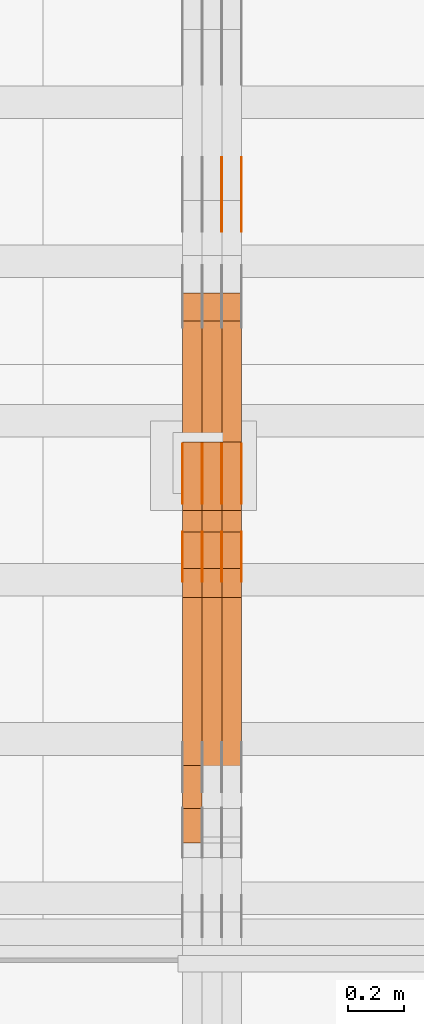
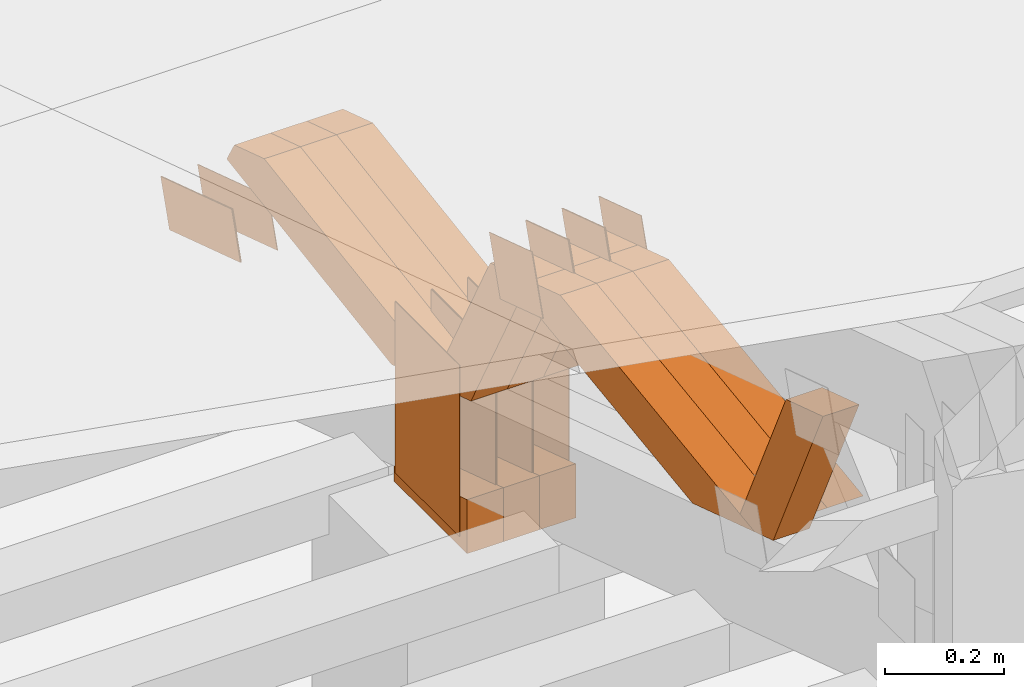
# One storey, part 151 of 385: 28 proxies.
"""IFC2X3 building model written with IfcOpenShell, lengths in millimetres."""

from ifc_helpers import new_model, entity, si_unit, converted_unit, derived_unit, direction, frame, origin, origin_2d_with_axis, place, context, subcontext, project, spatial, polyline, rectangle, outline, extrude, source, transform, mapped, material, type_object, type_shapes, element, save


model = new_model("IFC2X3")

# Units and contexts
model_context = context("Model", 3, precision=0.01, world=origin(), true_north=direction((6.12303176911189e-17, 1.0)))
body_context = subcontext(model_context, "Body", "Model", "MODEL_VIEW")
ifc_project = project(units=[si_unit("LENGTHUNIT", "METRE", prefix="MILLI"), si_unit("AREAUNIT", "SQUARE_METRE"), si_unit("VOLUMEUNIT", "CUBIC_METRE"), converted_unit("PLANEANGLEUNIT", "DEGREE", entity("IfcRatioMeasure", 0.0174532925199433), si_unit("PLANEANGLEUNIT", "RADIAN"), dimensions=[0, 0, 0, 0, 0, 0, 0]), si_unit("MASSUNIT", "GRAM", prefix="KILO"), derived_unit("MASSDENSITYUNIT", [(si_unit("MASSUNIT", "GRAM", prefix="KILO"), 1), (si_unit("LENGTHUNIT", "METRE"), -3)]), si_unit("TIMEUNIT", "SECOND"), si_unit("FREQUENCYUNIT", "HERTZ"), si_unit("THERMODYNAMICTEMPERATUREUNIT", "DEGREE_CELSIUS"), derived_unit("THERMALTRANSMITTANCEUNIT", [(si_unit("MASSUNIT", "GRAM", prefix="KILO"), 1), (si_unit("THERMODYNAMICTEMPERATUREUNIT", "KELVIN"), -1), (si_unit("TIMEUNIT", "SECOND"), -3)]), derived_unit("VOLUMETRICFLOWRATEUNIT", [(si_unit("LENGTHUNIT", "METRE"), 3), (si_unit("TIMEUNIT", "SECOND"), -1)]), si_unit("ELECTRICCURRENTUNIT", "AMPERE"), si_unit("ELECTRICVOLTAGEUNIT", "VOLT"), si_unit("POWERUNIT", "WATT"), si_unit("FORCEUNIT", "NEWTON", prefix="KILO"), si_unit("ILLUMINANCEUNIT", "LUX"), si_unit("LUMINOUSFLUXUNIT", "LUMEN"), si_unit("LUMINOUSINTENSITYUNIT", "CANDELA"), derived_unit("USERDEFINED", [(si_unit("MASSUNIT", "GRAM", prefix="KILO"), -1), (si_unit("LENGTHUNIT", "METRE"), -2), (si_unit("TIMEUNIT", "SECOND"), 3), (si_unit("LUMINOUSFLUXUNIT", "LUMEN"), 1)]), derived_unit("LINEARVELOCITYUNIT", [(si_unit("LENGTHUNIT", "METRE"), 1), (si_unit("TIMEUNIT", "SECOND"), -1)]), si_unit("PRESSUREUNIT", "PASCAL"), derived_unit("USERDEFINED", [(si_unit("LENGTHUNIT", "METRE"), -2), (si_unit("MASSUNIT", "GRAM", prefix="KILO"), 1), (si_unit("TIMEUNIT", "SECOND"), -2)])], contexts=[model_context])

# Site, building, storey
site_placement = place(None, origin())
site = spatial("IfcSite", under=ifc_project, at=site_placement, CompositionType="ELEMENT")
building_placement = place(site_placement, origin())
building = spatial("IfcBuilding", under=site, at=building_placement, CompositionType="ELEMENT")
storey_placement = place(building_placement, origin())
storey = spatial("IfcBuildingStorey", under=building, at=storey_placement, Name="Default", CompositionType="ELEMENT", Elevation=0.0)

# Proxies
ifc_material_1 = material(Name="IfcSurfaceStyle #273558")
building_element_proxy_type_1 = type_object("IfcBuildingElementProxyType", PredefinedType="NOTDEFINED", material=ifc_material_1)
shared_shape_1 = source(origin(), body_context, "Body", "SweptSolid", [
    extrude(outline(polyline([(-125.00031378339, -47.9999612158856), (125.000225258022, -47.9999612158856), (124.999811678525, 47.9999612158856), (-124.999723153156, 47.9999612158856), (-125.00031378339, -47.9999612158856)])), frame((125.000225258022, 48.0000091013474, 0.0), z_axis=(0.0, 0.0, 1.0), x_axis=(-1.0, 0.0, 0.0)), (0.0, 0.0, 1.0), 1.3),
])
type_shapes(building_element_proxy_type_1, [shared_shape_1])
proxy_1_placement = place(building_placement, frame((21386.3, 18456.8597683375, 2657.46691321253), z_axis=(-1.0, 0.0, 0.0), x_axis=(0.0, -0.951056516295124, 0.309016994375039)))
element("IfcBuildingElementProxy", 1, at=proxy_1_placement, inside=storey, type_object=building_element_proxy_type_1, material=ifc_material_1, context=body_context, shape_type="MappedRepresentation", body=[
    mapped(shared_shape_1, transform((0.0, 0.0, 0.0), scale=1.0)),
])
ifc_material_2 = material(Name="IfcSurfaceStyle #273501")
building_element_proxy_type_2 = type_object("IfcBuildingElementProxyType", PredefinedType="NOTDEFINED", material=ifc_material_2)
shared_shape_2 = source(origin(), body_context, "Body", "SweptSolid", [
    extrude(outline(polyline([(-125.00031378339, -47.9999612158856), (125.000225258022, -47.9999612158856), (124.999811678525, 47.9999612158856), (-124.999723153156, 47.9999612158856), (-125.00031378339, -47.9999612158856)])), frame((125.000225258022, 48.0000091013474, 0.0), z_axis=(0.0, 0.0, 1.0), x_axis=(-1.0, 0.0, 0.0)), (0.0, 0.0, 1.0), 1.3),
])
type_shapes(building_element_proxy_type_2, [shared_shape_2])
proxy_2_placement = place(building_placement, frame((21315.0, 18456.8597683375, 2657.46691321253), z_axis=(-1.0, 0.0, 0.0), x_axis=(0.0, -0.951056516295124, 0.309016994375039)))
element("IfcBuildingElementProxy", 2, at=proxy_2_placement, inside=storey, type_object=building_element_proxy_type_2, material=ifc_material_2, context=body_context, shape_type="MappedRepresentation", body=[
    mapped(shared_shape_2, transform((0.0, 0.0, 0.0), scale=1.0)),
])
ifc_material_3 = material(Name="IfcSurfaceStyle #273444")
building_element_proxy_type_3 = type_object("IfcBuildingElementProxyType", PredefinedType="NOTDEFINED", material=ifc_material_3)
shared_shape_3 = source(origin(), body_context, "Body", "SweptSolid", [
    extrude(outline(polyline([(-125.00031378339, -47.9999612158856), (125.000225258022, -47.9999612158856), (124.999811678525, 47.9999612158856), (-124.999723153156, 47.9999612158856), (-125.00031378339, -47.9999612158856)])), frame((125.000225258022, 48.0000091013474, 0.0), z_axis=(0.0, 0.0, 1.0), x_axis=(-1.0, 0.0, 0.0)), (0.0, 0.0, 1.0), 1.3),
])
type_shapes(building_element_proxy_type_3, [shared_shape_3])
proxy_3_placement = place(building_placement, frame((21316.3, 18456.8597683375, 2657.46691321253), z_axis=(-1.0, 0.0, 0.0), x_axis=(0.0, -0.951056516295124, 0.309016994375039)))
element("IfcBuildingElementProxy", 3, at=proxy_3_placement, inside=storey, type_object=building_element_proxy_type_3, material=ifc_material_3, context=body_context, shape_type="MappedRepresentation", body=[
    mapped(shared_shape_3, transform((0.0, 0.0, 0.0), scale=1.0)),
])
ifc_material_4 = material(Name="IfcSurfaceStyle #271506")
building_element_proxy_type_4 = type_object("IfcBuildingElementProxyType", PredefinedType="NOTDEFINED", material=ifc_material_4)
shared_shape_4 = source(origin(), body_context, "Body", "SweptSolid", [
    extrude(rectangle(XDim=350.0, YDim=215.999999999984, at=origin_2d_with_axis()), frame((175.0, 108.0, 0.0), z_axis=(0.0, 0.0, 1.0), x_axis=(-1.0, 0.0, 0.0)), (0.0, 0.0, 1.0), 1.29999999999999),
])
type_shapes(building_element_proxy_type_4, [shared_shape_4])
proxy_4_placement = place(building_placement, frame((21386.3, 17459.2939453125, 3165.36425781251), z_axis=(-1.0, 0.0, 0.0), x_axis=(0.0, 0.0, -1.0)))
element("IfcBuildingElementProxy", 4, at=proxy_4_placement, inside=storey, type_object=building_element_proxy_type_4, material=ifc_material_4, context=body_context, shape_type="MappedRepresentation", body=[
    mapped(shared_shape_4, transform((0.0, 0.0, 0.0), scale=1.0)),
])
ifc_material_5 = material(Name="IfcSurfaceStyle #271449")
building_element_proxy_type_5 = type_object("IfcBuildingElementProxyType", PredefinedType="NOTDEFINED", material=ifc_material_5)
shared_shape_5 = source(origin(), body_context, "Body", "SweptSolid", [
    extrude(rectangle(XDim=350.0, YDim=215.999999999984, at=origin_2d_with_axis()), frame((175.0, 108.0, 0.0), z_axis=(0.0, 0.0, 1.0), x_axis=(-1.0, 0.0, 0.0)), (0.0, 0.0, 1.0), 1.29999999999999),
])
type_shapes(building_element_proxy_type_5, [shared_shape_5])
proxy_5_placement = place(building_placement, frame((21315.0, 17459.2939453125, 3165.36425781251), z_axis=(-1.0, 0.0, 0.0), x_axis=(0.0, 0.0, -1.0)))
element("IfcBuildingElementProxy", 5, at=proxy_5_placement, inside=storey, type_object=building_element_proxy_type_5, material=ifc_material_5, context=body_context, shape_type="MappedRepresentation", body=[
    mapped(shared_shape_5, transform((0.0, 0.0, 0.0), scale=1.0)),
])
ifc_material_6 = material(Name="IfcSurfaceStyle #271392")
building_element_proxy_type_6 = type_object("IfcBuildingElementProxyType", PredefinedType="NOTDEFINED", material=ifc_material_6)
shared_shape_6 = source(origin(), body_context, "Body", "SweptSolid", [
    extrude(rectangle(XDim=350.0, YDim=215.999999999984, at=origin_2d_with_axis()), frame((175.0, 108.0, 0.0), z_axis=(0.0, 0.0, 1.0), x_axis=(-1.0, 0.0, 0.0)), (0.0, 0.0, 1.0), 1.29999999999999),
])
type_shapes(building_element_proxy_type_6, [shared_shape_6])
proxy_6_placement = place(building_placement, frame((21316.3, 17459.2939453125, 3165.36425781251), z_axis=(-1.0, 0.0, 0.0), x_axis=(0.0, 0.0, -1.0)))
element("IfcBuildingElementProxy", 6, at=proxy_6_placement, inside=storey, type_object=building_element_proxy_type_6, material=ifc_material_6, context=body_context, shape_type="MappedRepresentation", body=[
    mapped(shared_shape_6, transform((0.0, 0.0, 0.0), scale=1.0)),
])
ifc_material_7 = material(Name="IfcSurfaceStyle #271335")
building_element_proxy_type_7 = type_object("IfcBuildingElementProxyType", PredefinedType="NOTDEFINED", material=ifc_material_7)
shared_shape_7 = source(origin(), body_context, "Body", "SweptSolid", [
    extrude(rectangle(XDim=350.0, YDim=215.999999999984, at=origin_2d_with_axis()), frame((175.0, 108.0, 0.0), z_axis=(0.0, 0.0, 1.0), x_axis=(-1.0, 0.0, 0.0)), (0.0, 0.0, 1.0), 1.29999999999998),
])
type_shapes(building_element_proxy_type_7, [shared_shape_7])
proxy_7_placement = place(building_placement, frame((21245.0, 17459.2939453125, 3165.36425781251), z_axis=(-1.0, 0.0, 0.0), x_axis=(0.0, 0.0, -1.0)))
element("IfcBuildingElementProxy", 7, at=proxy_7_placement, inside=storey, type_object=building_element_proxy_type_7, material=ifc_material_7, context=body_context, shape_type="MappedRepresentation", body=[
    mapped(shared_shape_7, transform((0.0, 0.0, 0.0), scale=1.0)),
])
ifc_material_8 = material(Name="IfcSurfaceStyle #271278")
building_element_proxy_type_8 = type_object("IfcBuildingElementProxyType", PredefinedType="NOTDEFINED", material=ifc_material_8)
shared_shape_8 = source(origin(), body_context, "Body", "SweptSolid", [
    extrude(rectangle(XDim=350.0, YDim=215.999999999984, at=origin_2d_with_axis()), frame((175.0, 108.0, 0.0), z_axis=(0.0, 0.0, 1.0), x_axis=(-1.0, 0.0, 0.0)), (0.0, 0.0, 1.0), 1.29999999999998),
])
type_shapes(building_element_proxy_type_8, [shared_shape_8])
proxy_8_placement = place(building_placement, frame((21246.3, 17459.2939453125, 3165.36425781251), z_axis=(-1.0, 0.0, 0.0), x_axis=(0.0, 0.0, -1.0)))
element("IfcBuildingElementProxy", 8, at=proxy_8_placement, inside=storey, type_object=building_element_proxy_type_8, material=ifc_material_8, context=body_context, shape_type="MappedRepresentation", body=[
    mapped(shared_shape_8, transform((0.0, 0.0, 0.0), scale=1.0)),
])
ifc_material_9 = material(Name="IfcSurfaceStyle #271221")
building_element_proxy_type_9 = type_object("IfcBuildingElementProxyType", PredefinedType="NOTDEFINED", material=ifc_material_9)
shared_shape_9 = source(origin(), body_context, "Body", "SweptSolid", [
    extrude(rectangle(XDim=350.0, YDim=215.999999999984, at=origin_2d_with_axis()), frame((175.0, 108.0, 0.0), z_axis=(0.0, 0.0, 1.0), x_axis=(-1.0, 0.0, 0.0)), (0.0, 0.0, 1.0), 1.29999999999998),
])
type_shapes(building_element_proxy_type_9, [shared_shape_9])
proxy_9_placement = place(building_placement, frame((21175.0, 17459.2939453125, 3165.36425781251), z_axis=(-1.0, 0.0, 0.0), x_axis=(0.0, 0.0, -1.0)))
element("IfcBuildingElementProxy", 9, at=proxy_9_placement, inside=storey, type_object=building_element_proxy_type_9, material=ifc_material_9, context=body_context, shape_type="MappedRepresentation", body=[
    mapped(shared_shape_9, transform((0.0, 0.0, 0.0), scale=1.0)),
])
ifc_material_10 = material(Name="IfcSurfaceStyle #268086")
building_element_proxy_type_10 = type_object("IfcBuildingElementProxyType", PredefinedType="NOTDEFINED", material=ifc_material_10)
shared_shape_10 = source(origin(), body_context, "Body", "SweptSolid", [
    extrude(outline(polyline([(-74.9998605591058, -59.9999264677524), (74.999875428623, -59.9999264677524), (74.9998605591068, 59.9999264677524), (-74.9998754286239, 59.9999264677524), (-74.9998605591058, -59.9999264677524)])), frame((75.0002460484325, 60.0000016373508, 0.0), z_axis=(0.0, 0.0, 1.0), x_axis=(-1.0, 0.0, 0.0)), (0.0, 0.0, 1.0), 1.3),
])
type_shapes(building_element_proxy_type_10, [shared_shape_10])
proxy_10_placement = place(building_placement, frame((21386.3, 17107.0599369346, 3383.82825001787), z_axis=(-1.0, 0.0, 0.0), x_axis=(0.0, -0.951056516295154, 0.309016994374948)))
element("IfcBuildingElementProxy", 10, at=proxy_10_placement, inside=storey, type_object=building_element_proxy_type_10, material=ifc_material_10, context=body_context, shape_type="MappedRepresentation", body=[
    mapped(shared_shape_10, transform((0.0, 0.0, 0.0), scale=1.0)),
])
ifc_material_11 = material(Name="IfcSurfaceStyle #268029")
building_element_proxy_type_11 = type_object("IfcBuildingElementProxyType", PredefinedType="NOTDEFINED", material=ifc_material_11)
shared_shape_11 = source(origin(), body_context, "Body", "SweptSolid", [
    extrude(outline(polyline([(-74.9998605591058, -59.9999264677524), (74.999875428623, -59.9999264677524), (74.9998605591068, 59.9999264677524), (-74.9998754286239, 59.9999264677524), (-74.9998605591058, -59.9999264677524)])), frame((75.0002460484325, 60.0000016373508, 0.0), z_axis=(0.0, 0.0, 1.0), x_axis=(-1.0, 0.0, 0.0)), (0.0, 0.0, 1.0), 1.3),
])
type_shapes(building_element_proxy_type_11, [shared_shape_11])
proxy_11_placement = place(building_placement, frame((21315.0, 17107.0599369346, 3383.82825001787), z_axis=(-1.0, 0.0, 0.0), x_axis=(0.0, -0.951056516295154, 0.309016994374948)))
element("IfcBuildingElementProxy", 11, at=proxy_11_placement, inside=storey, type_object=building_element_proxy_type_11, material=ifc_material_11, context=body_context, shape_type="MappedRepresentation", body=[
    mapped(shared_shape_11, transform((0.0, 0.0, 0.0), scale=1.0)),
])
ifc_material_12 = material(Name="IfcSurfaceStyle #267972")
building_element_proxy_type_12 = type_object("IfcBuildingElementProxyType", PredefinedType="NOTDEFINED", material=ifc_material_12)
shared_shape_12 = source(origin(), body_context, "Body", "SweptSolid", [
    extrude(outline(polyline([(-74.9998605591058, -59.9999264677524), (74.999875428623, -59.9999264677524), (74.9998605591068, 59.9999264677524), (-74.9998754286239, 59.9999264677524), (-74.9998605591058, -59.9999264677524)])), frame((75.0002460484325, 60.0000016373508, 0.0), z_axis=(0.0, 0.0, 1.0), x_axis=(-1.0, 0.0, 0.0)), (0.0, 0.0, 1.0), 1.3),
])
type_shapes(building_element_proxy_type_12, [shared_shape_12])
proxy_12_placement = place(building_placement, frame((21316.3, 17107.0599369346, 3383.82825001787), z_axis=(-1.0, 0.0, 0.0), x_axis=(0.0, -0.951056516295154, 0.309016994374948)))
element("IfcBuildingElementProxy", 12, at=proxy_12_placement, inside=storey, type_object=building_element_proxy_type_12, material=ifc_material_12, context=body_context, shape_type="MappedRepresentation", body=[
    mapped(shared_shape_12, transform((0.0, 0.0, 0.0), scale=1.0)),
])
ifc_material_13 = material(Name="IfcSurfaceStyle #267915")
building_element_proxy_type_13 = type_object("IfcBuildingElementProxyType", PredefinedType="NOTDEFINED", material=ifc_material_13)
shared_shape_13 = source(origin(), body_context, "Body", "SweptSolid", [
    extrude(outline(polyline([(-74.9998605591058, -59.9999264677524), (74.999875428623, -59.9999264677524), (74.9998605591068, 59.9999264677524), (-74.9998754286239, 59.9999264677524), (-74.9998605591058, -59.9999264677524)])), frame((75.0002460484325, 60.0000016373508, 0.0), z_axis=(0.0, 0.0, 1.0), x_axis=(-1.0, 0.0, 0.0)), (0.0, 0.0, 1.0), 1.29999999999999),
])
type_shapes(building_element_proxy_type_13, [shared_shape_13])
proxy_13_placement = place(building_placement, frame((21245.0, 17107.0599369346, 3383.82825001787), z_axis=(-1.0, 0.0, 0.0), x_axis=(0.0, -0.951056516295154, 0.309016994374948)))
element("IfcBuildingElementProxy", 13, at=proxy_13_placement, inside=storey, type_object=building_element_proxy_type_13, material=ifc_material_13, context=body_context, shape_type="MappedRepresentation", body=[
    mapped(shared_shape_13, transform((0.0, 0.0, 0.0), scale=1.0)),
])
ifc_material_14 = material(Name="IfcSurfaceStyle #267858")
building_element_proxy_type_14 = type_object("IfcBuildingElementProxyType", PredefinedType="NOTDEFINED", material=ifc_material_14)
shared_shape_14 = source(origin(), body_context, "Body", "SweptSolid", [
    extrude(outline(polyline([(-74.9998605591058, -59.9999264677524), (74.999875428623, -59.9999264677524), (74.9998605591068, 59.9999264677524), (-74.9998754286239, 59.9999264677524), (-74.9998605591058, -59.9999264677524)])), frame((75.0002460484325, 60.0000016373508, 0.0), z_axis=(0.0, 0.0, 1.0), x_axis=(-1.0, 0.0, 0.0)), (0.0, 0.0, 1.0), 1.29999999999999),
])
type_shapes(building_element_proxy_type_14, [shared_shape_14])
proxy_14_placement = place(building_placement, frame((21246.3, 17107.0599369346, 3383.82825001787), z_axis=(-1.0, 0.0, 0.0), x_axis=(0.0, -0.951056516295154, 0.309016994374948)))
element("IfcBuildingElementProxy", 14, at=proxy_14_placement, inside=storey, type_object=building_element_proxy_type_14, material=ifc_material_14, context=body_context, shape_type="MappedRepresentation", body=[
    mapped(shared_shape_14, transform((0.0, 0.0, 0.0), scale=1.0)),
])
ifc_material_15 = material(Name="IfcSurfaceStyle #267801")
building_element_proxy_type_15 = type_object("IfcBuildingElementProxyType", PredefinedType="NOTDEFINED", material=ifc_material_15)
shared_shape_15 = source(origin(), body_context, "Body", "SweptSolid", [
    extrude(outline(polyline([(-74.9998605591058, -59.9999264677524), (74.999875428623, -59.9999264677524), (74.9998605591068, 59.9999264677524), (-74.9998754286239, 59.9999264677524), (-74.9998605591058, -59.9999264677524)])), frame((75.0002460484325, 60.0000016373508, 0.0), z_axis=(0.0, 0.0, 1.0), x_axis=(-1.0, 0.0, 0.0)), (0.0, 0.0, 1.0), 1.29999999999999),
])
type_shapes(building_element_proxy_type_15, [shared_shape_15])
proxy_15_placement = place(building_placement, frame((21175.0, 17107.0599369346, 3383.82825001787), z_axis=(-1.0, 0.0, 0.0), x_axis=(0.0, -0.951056516295154, 0.309016994374948)))
element("IfcBuildingElementProxy", 15, at=proxy_15_placement, inside=storey, type_object=building_element_proxy_type_15, material=ifc_material_15, context=body_context, shape_type="MappedRepresentation", body=[
    mapped(shared_shape_15, transform((0.0, 0.0, 0.0), scale=1.0)),
])
ifc_material_16 = material(Name="IfcSurfaceStyle #259797")
building_element_proxy_type_16 = type_object("IfcBuildingElementProxyType", Name="T1-E1 259795", PredefinedType="NOTDEFINED", material=ifc_material_16)
shared_shape_16 = source(origin(), body_context, "Body", "SweptSolid", [
    extrude(outline(polyline([(4.4675903320374, -122.500000000001), (35.3350219726624, -122.500000000001), (35.3350219726501, 122.500000000001), (-75.1376342773499, 122.500000000001), (4.4675903320374, -122.500000000001)])), frame((35.3350219726624, 122.50000005215, 0.0), z_axis=(0.0, 0.0, 1.0), x_axis=(-1.0, 0.0, 0.0)), (0.0, 0.0, 1.0), 70.0),
])
type_shapes(building_element_proxy_type_16, [shared_shape_16])
proxy_16_placement = place(building_placement, frame((21385.0, 17220.0, 2794.30932617186), z_axis=(-1.0, 0.0, 0.0), x_axis=(0.0, 0.0, 1.0)))
element("IfcBuildingElementProxy", 16, at=proxy_16_placement, inside=storey, type_object=building_element_proxy_type_16, material=ifc_material_16, Name="T1-E1", context=body_context, shape_type="MappedRepresentation", body=[
    mapped(shared_shape_16, transform((0.0, 0.0, 0.0), scale=1.0)),
])
ifc_material_17 = material(Name="IfcSurfaceStyle #259740")
building_element_proxy_type_17 = type_object("IfcBuildingElementProxyType", Name="T1-E1 259738", PredefinedType="NOTDEFINED", material=ifc_material_17)
shared_shape_17 = source(origin(), body_context, "Body", "SweptSolid", [
    extrude(outline(polyline([(4.4675903320374, -122.500000000001), (35.3350219726624, -122.500000000001), (35.3350219726501, 122.500000000001), (-75.1376342773499, 122.500000000001), (4.4675903320374, -122.500000000001)])), frame((35.3350219726624, 122.50000005215, 0.0), z_axis=(0.0, 0.0, 1.0), x_axis=(-1.0, 0.0, 0.0)), (0.0, 0.0, 1.0), 70.0),
])
type_shapes(building_element_proxy_type_17, [shared_shape_17])
proxy_17_placement = place(building_placement, frame((21315.0, 17220.0, 2794.30932617186), z_axis=(-1.0, 0.0, 0.0), x_axis=(0.0, 0.0, 1.0)))
element("IfcBuildingElementProxy", 17, at=proxy_17_placement, inside=storey, type_object=building_element_proxy_type_17, material=ifc_material_17, Name="T1-E1", context=body_context, shape_type="MappedRepresentation", body=[
    mapped(shared_shape_17, transform((0.0, 0.0, 0.0), scale=1.0)),
])
ifc_material_18 = material(Name="IfcSurfaceStyle #259683")
building_element_proxy_type_18 = type_object("IfcBuildingElementProxyType", Name="T1-E1 259681", PredefinedType="NOTDEFINED", material=ifc_material_18)
shared_shape_18 = source(origin(), body_context, "Body", "SweptSolid", [
    extrude(outline(polyline([(4.4675903320374, -122.500000000001), (35.3350219726624, -122.500000000001), (35.3350219726501, 122.500000000001), (-75.1376342773499, 122.500000000001), (4.4675903320374, -122.500000000001)])), frame((35.3350219726624, 122.50000005215, 0.0), z_axis=(0.0, 0.0, 1.0), x_axis=(-1.0, 0.0, 0.0)), (0.0, 0.0, 1.0), 70.0),
])
type_shapes(building_element_proxy_type_18, [shared_shape_18])
proxy_18_placement = place(building_placement, frame((21245.0, 17220.0, 2794.30932617186), z_axis=(-1.0, 0.0, 0.0), x_axis=(0.0, 0.0, 1.0)))
element("IfcBuildingElementProxy", 18, at=proxy_18_placement, inside=storey, type_object=building_element_proxy_type_18, material=ifc_material_18, Name="T1-E1", context=body_context, shape_type="MappedRepresentation", body=[
    mapped(shared_shape_18, transform((0.0, 0.0, 0.0), scale=1.0)),
])
ifc_material_19 = material(Name="IfcSurfaceStyle #258702")
building_element_proxy_type_19 = type_object("IfcBuildingElementProxyType", Name="T1-W44 258700", PredefinedType="NOTDEFINED", material=ifc_material_19)
shared_shape_19 = source(origin(), body_context, "Body", "SweptSolid", [
    extrude(outline(polyline([(-184.551057772692, -47.4997984945814), (177.527112951531, -47.4997984945814), (162.630077773546, -0.000452497529500495), (118.068221667048, 47.5000247433462), (-273.674354619433, 47.5000247433462), (-184.551057772692, -47.4997984945814)])), frame((177.527112951531, 47.5002721629815, 0.0), z_axis=(0.0, 0.0, 1.0), x_axis=(-1.0, 0.0, 0.0)), (0.0, 0.0, 1.0), 70.0),
])
type_shapes(building_element_proxy_type_19, [shared_shape_19])
proxy_19_placement = place(building_placement, frame((21245.0, 16220.4899216004, 3388.98238154171), z_axis=(-1.0, 0.0, 0.0), x_axis=(0.0, -0.425335045192995, 0.905035965766374)))
element("IfcBuildingElementProxy", 19, at=proxy_19_placement, inside=storey, type_object=building_element_proxy_type_19, material=ifc_material_19, Name="T1-W44", context=body_context, shape_type="MappedRepresentation", body=[
    mapped(shared_shape_19, transform((0.0, 0.0, 0.0), scale=1.0)),
])
ifc_material_20 = material(Name="IfcSurfaceStyle #258438")
building_element_proxy_type_20 = type_object("IfcBuildingElementProxyType", Name="T1-W8 258436", PredefinedType="NOTDEFINED", material=ifc_material_20)
shared_shape_20 = source(origin(), body_context, "Body", "SweptSolid", [
    extrude(outline(polyline([(-476.725263324644, -47.5001051695965), (180.672765845439, -47.5001051695965), (279.11020091716, -1.03605560390907e-06), (296.793624402619, 47.5001056876243), (-279.851327840575, 47.5001056876243), (-476.725263324644, -47.5001051695965)])), frame((296.793624402619, 47.5001056876243, 0.0), z_axis=(0.0, 0.0, 1.0), x_axis=(-1.0, 0.0, 0.0)), (0.0, 0.0, 1.0), 70.0),
])
type_shapes(building_element_proxy_type_20, [shared_shape_20])
proxy_20_placement = place(building_placement, frame((21385.0, 17036.40625, 3432.97192382813), z_axis=(-1.0, 0.0, 0.0), x_axis=(0.0, -0.990844046556832, -0.135011389900564)))
element("IfcBuildingElementProxy", 20, at=proxy_20_placement, inside=storey, type_object=building_element_proxy_type_20, material=ifc_material_20, Name="T1-W8", context=body_context, shape_type="MappedRepresentation", body=[
    mapped(shared_shape_20, transform((0.0, 0.0, 0.0), scale=1.0)),
])
ifc_material_21 = material(Name="IfcSurfaceStyle #258372")
building_element_proxy_type_21 = type_object("IfcBuildingElementProxyType", Name="T1-W8 258370", PredefinedType="NOTDEFINED", material=ifc_material_21)
shared_shape_21 = source(origin(), body_context, "Body", "SweptSolid", [
    extrude(outline(polyline([(-476.725263324644, -47.5001051695965), (180.672765845439, -47.5001051695965), (279.11020091716, -1.03605560390907e-06), (296.793624402619, 47.5001056876243), (-279.851327840575, 47.5001056876243), (-476.725263324644, -47.5001051695965)])), frame((296.793624402619, 47.5001056876243, 0.0), z_axis=(0.0, 0.0, 1.0), x_axis=(-1.0, 0.0, 0.0)), (0.0, 0.0, 1.0), 70.0),
])
type_shapes(building_element_proxy_type_21, [shared_shape_21])
proxy_21_placement = place(building_placement, frame((21315.0, 17036.40625, 3432.97192382813), z_axis=(-1.0, 0.0, 0.0), x_axis=(0.0, -0.990844046556832, -0.135011389900564)))
element("IfcBuildingElementProxy", 21, at=proxy_21_placement, inside=storey, type_object=building_element_proxy_type_21, material=ifc_material_21, Name="T1-W8", context=body_context, shape_type="MappedRepresentation", body=[
    mapped(shared_shape_21, transform((0.0, 0.0, 0.0), scale=1.0)),
])
ifc_material_22 = material(Name="IfcSurfaceStyle #258306")
building_element_proxy_type_22 = type_object("IfcBuildingElementProxyType", Name="T1-W8 258304", PredefinedType="NOTDEFINED", material=ifc_material_22)
shared_shape_22 = source(origin(), body_context, "Body", "SweptSolid", [
    extrude(outline(polyline([(-476.725263324644, -47.5001051695965), (180.672765845439, -47.5001051695965), (279.11020091716, -1.03605560390907e-06), (296.793624402619, 47.5001056876243), (-279.851327840575, 47.5001056876243), (-476.725263324644, -47.5001051695965)])), frame((296.793624402619, 47.5001056876243, 0.0), z_axis=(0.0, 0.0, 1.0), x_axis=(-1.0, 0.0, 0.0)), (0.0, 0.0, 1.0), 70.0),
])
type_shapes(building_element_proxy_type_22, [shared_shape_22])
proxy_22_placement = place(building_placement, frame((21245.0, 17036.40625, 3432.97192382813), z_axis=(-1.0, 0.0, 0.0), x_axis=(0.0, -0.990844046556832, -0.135011389900564)))
element("IfcBuildingElementProxy", 22, at=proxy_22_placement, inside=storey, type_object=building_element_proxy_type_22, material=ifc_material_22, Name="T1-W8", context=body_context, shape_type="MappedRepresentation", body=[
    mapped(shared_shape_22, transform((0.0, 0.0, 0.0), scale=1.0)),
])
ifc_material_23 = material(Name="IfcSurfaceStyle #258042")
building_element_proxy_type_23 = type_object("IfcBuildingElementProxyType", Name="T1-W39 258040", PredefinedType="NOTDEFINED", material=ifc_material_23)
shared_shape_23 = source(origin(), body_context, "Body", "SweptSolid", [
    extrude(outline(polyline([(-191.519946663886, -47.499928106579), (188.32936223763, -47.499928106579), (171.597440144109, 0.000249483340993841), (122.102882529753, 47.4998033649085), (-290.509738247605, 47.4998033649085), (-191.519946663886, -47.499928106579)])), frame((188.329593252001, 47.499957247623, 0.0), z_axis=(0.0, 0.0, 1.0), x_axis=(-1.0, 0.0, 0.0)), (0.0, 0.0, 1.0), 70.0),
])
type_shapes(building_element_proxy_type_23, [shared_shape_23])
proxy_23_placement = place(building_placement, frame((21385.0, 17238.5876916597, 3055.56121424762), z_axis=(-1.0, 0.0, 0.0), x_axis=(0.0, -0.472216932390777, 0.881482370080902)))
element("IfcBuildingElementProxy", 23, at=proxy_23_placement, inside=storey, type_object=building_element_proxy_type_23, material=ifc_material_23, Name="T1-W39", context=body_context, shape_type="MappedRepresentation", body=[
    mapped(shared_shape_23, transform((0.0, 0.0, 0.0), scale=1.0)),
])
ifc_material_24 = material(Name="IfcSurfaceStyle #257976")
building_element_proxy_type_24 = type_object("IfcBuildingElementProxyType", Name="T1-W39 257974", PredefinedType="NOTDEFINED", material=ifc_material_24)
shared_shape_24 = source(origin(), body_context, "Body", "SweptSolid", [
    extrude(outline(polyline([(-191.519946663886, -47.499928106579), (188.32936223763, -47.499928106579), (171.597440144109, 0.000249483340993841), (122.102882529753, 47.4998033649085), (-290.509738247605, 47.4998033649085), (-191.519946663886, -47.499928106579)])), frame((188.329593252001, 47.499957247623, 0.0), z_axis=(0.0, 0.0, 1.0), x_axis=(-1.0, 0.0, 0.0)), (0.0, 0.0, 1.0), 70.0),
])
type_shapes(building_element_proxy_type_24, [shared_shape_24])
proxy_24_placement = place(building_placement, frame((21315.0, 17238.5876916597, 3055.56121424762), z_axis=(-1.0, 0.0, 0.0), x_axis=(0.0, -0.472216932390777, 0.881482370080902)))
element("IfcBuildingElementProxy", 24, at=proxy_24_placement, inside=storey, type_object=building_element_proxy_type_24, material=ifc_material_24, Name="T1-W39", context=body_context, shape_type="MappedRepresentation", body=[
    mapped(shared_shape_24, transform((0.0, 0.0, 0.0), scale=1.0)),
])
ifc_material_25 = material(Name="IfcSurfaceStyle #257910")
building_element_proxy_type_25 = type_object("IfcBuildingElementProxyType", Name="T1-W39 257908", PredefinedType="NOTDEFINED", material=ifc_material_25)
shared_shape_25 = source(origin(), body_context, "Body", "SweptSolid", [
    extrude(outline(polyline([(-191.519946663886, -47.499928106579), (188.32936223763, -47.499928106579), (171.597440144109, 0.000249483340993841), (122.102882529753, 47.4998033649085), (-290.509738247605, 47.4998033649085), (-191.519946663886, -47.499928106579)])), frame((188.329593252001, 47.499957247623, 0.0), z_axis=(0.0, 0.0, 1.0), x_axis=(-1.0, 0.0, 0.0)), (0.0, 0.0, 1.0), 70.0),
])
type_shapes(building_element_proxy_type_25, [shared_shape_25])
proxy_25_placement = place(building_placement, frame((21245.0, 17238.5876916597, 3055.56121424762), z_axis=(-1.0, 0.0, 0.0), x_axis=(0.0, -0.472216932390777, 0.881482370080902)))
element("IfcBuildingElementProxy", 25, at=proxy_25_placement, inside=storey, type_object=building_element_proxy_type_25, material=ifc_material_25, Name="T1-W39", context=body_context, shape_type="MappedRepresentation", body=[
    mapped(shared_shape_25, transform((0.0, 0.0, 0.0), scale=1.0)),
])
ifc_material_26 = material(Name="IfcSurfaceStyle #257646")
building_element_proxy_type_26 = type_object("IfcBuildingElementProxyType", Name="T1-W10 257644", PredefinedType="NOTDEFINED", material=ifc_material_26)
shared_shape_26 = source(origin(), body_context, "Body", "SweptSolid", [
    extrude(outline(polyline([(-459.546036710757, -47.5000436364511), (174.689450869018, -47.5000436364511), (268.831081103959, 0.00011114562912502), (287.286350706789, 47.4999880636365), (-271.260845969009, 47.4999880636366), (-459.546036710757, -47.5000436364511)])), frame((287.286768781132, 47.5001637448091, 0.0), z_axis=(0.0, 0.0, 1.0), x_axis=(-1.0, 0.0, 0.0)), (0.0, 0.0, 1.0), 70.0),
])
type_shapes(building_element_proxy_type_26, [shared_shape_26])
proxy_26_placement = place(building_placement, frame((21385.0, 18025.1410649788, 3112.76453857986), z_axis=(-1.0, 0.0, 0.0), x_axis=(0.0, -0.988299196256916, -0.152527698068035)))
element("IfcBuildingElementProxy", 26, at=proxy_26_placement, inside=storey, type_object=building_element_proxy_type_26, material=ifc_material_26, Name="T1-W10", context=body_context, shape_type="MappedRepresentation", body=[
    mapped(shared_shape_26, transform((0.0, 0.0, 0.0), scale=1.0)),
])
ifc_material_27 = material(Name="IfcSurfaceStyle #257580")
building_element_proxy_type_27 = type_object("IfcBuildingElementProxyType", Name="T1-W10 257578", PredefinedType="NOTDEFINED", material=ifc_material_27)
shared_shape_27 = source(origin(), body_context, "Body", "SweptSolid", [
    extrude(outline(polyline([(-459.546036710757, -47.5000436364511), (174.689450869018, -47.5000436364511), (268.831081103959, 0.00011114562912502), (287.286350706789, 47.4999880636365), (-271.260845969009, 47.4999880636366), (-459.546036710757, -47.5000436364511)])), frame((287.286768781132, 47.5001637448091, 0.0), z_axis=(0.0, 0.0, 1.0), x_axis=(-1.0, 0.0, 0.0)), (0.0, 0.0, 1.0), 70.0),
])
type_shapes(building_element_proxy_type_27, [shared_shape_27])
proxy_27_placement = place(building_placement, frame((21315.0, 18025.1410649788, 3112.76453857986), z_axis=(-1.0, 0.0, 0.0), x_axis=(0.0, -0.988299196256916, -0.152527698068035)))
element("IfcBuildingElementProxy", 27, at=proxy_27_placement, inside=storey, type_object=building_element_proxy_type_27, material=ifc_material_27, Name="T1-W10", context=body_context, shape_type="MappedRepresentation", body=[
    mapped(shared_shape_27, transform((0.0, 0.0, 0.0), scale=1.0)),
])
ifc_material_28 = material(Name="IfcSurfaceStyle #257514")
building_element_proxy_type_28 = type_object("IfcBuildingElementProxyType", Name="T1-W10 257512", PredefinedType="NOTDEFINED", material=ifc_material_28)
shared_shape_28 = source(origin(), body_context, "Body", "SweptSolid", [
    extrude(outline(polyline([(-459.546036710757, -47.5000436364511), (174.689450869018, -47.5000436364511), (268.831081103959, 0.00011114562912502), (287.286350706789, 47.4999880636365), (-271.260845969009, 47.4999880636366), (-459.546036710757, -47.5000436364511)])), frame((287.286768781132, 47.5001637448091, 0.0), z_axis=(0.0, 0.0, 1.0), x_axis=(-1.0, 0.0, 0.0)), (0.0, 0.0, 1.0), 70.0),
])
type_shapes(building_element_proxy_type_28, [shared_shape_28])
proxy_28_placement = place(building_placement, frame((21245.0, 18025.1410649788, 3112.76453857986), z_axis=(-1.0, 0.0, 0.0), x_axis=(0.0, -0.988299196256916, -0.152527698068035)))
element("IfcBuildingElementProxy", 28, at=proxy_28_placement, inside=storey, type_object=building_element_proxy_type_28, material=ifc_material_28, Name="T1-W10", context=body_context, shape_type="MappedRepresentation", body=[
    mapped(shared_shape_28, transform((0.0, 0.0, 0.0), scale=1.0)),
])

save(model, "model.ifc")
